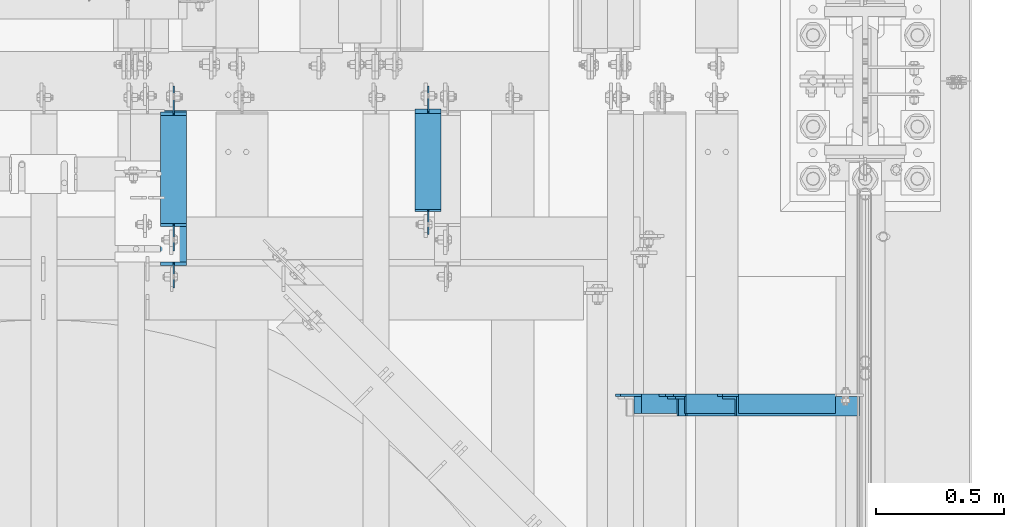
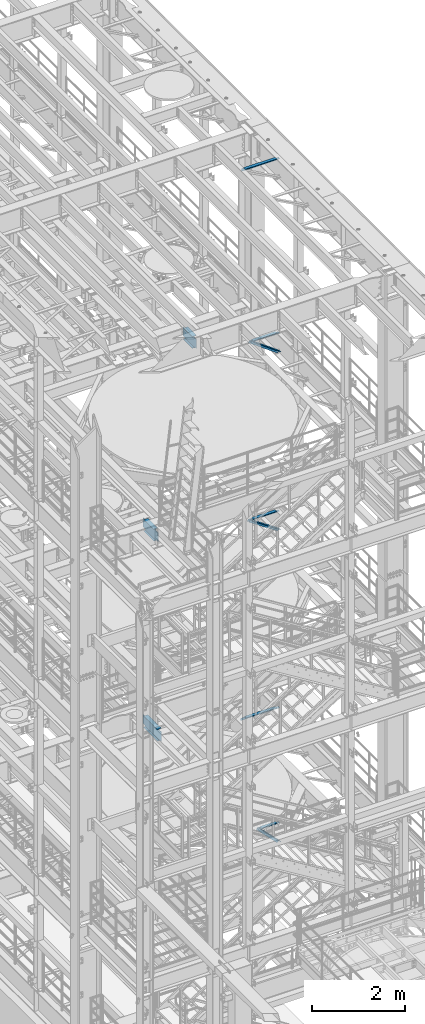
# One storey, part 1241 of 1876: 8 beams, 3 members, 11 elements without a shape of their own.
"""IFC2X3 building model written with IfcOpenShell, lengths in millimetres."""

from ifc_helpers import new_model, si_unit, frame, origin_with_axes, place, context, subcontext, project, spatial, faceted_brep, material, type_object, element, aggregate, save


model = new_model("IFC2X3")

# Units and contexts
model_context = context("Model", 3, precision=1e-05, world=origin_with_axes())
body_context = subcontext(model_context, "Body", "Model", "MODEL_VIEW")
ifc_project = project(units=[si_unit("LENGTHUNIT", "METRE", prefix="MILLI"), si_unit("AREAUNIT", "SQUARE_METRE"), si_unit("VOLUMEUNIT", "CUBIC_METRE"), si_unit("MASSUNIT", "GRAM", prefix="KILO"), si_unit("TIMEUNIT", "SECOND"), si_unit("PLANEANGLEUNIT", "RADIAN"), si_unit("SOLIDANGLEUNIT", "STERADIAN"), si_unit("THERMODYNAMICTEMPERATUREUNIT", "DEGREE_CELSIUS"), si_unit("LUMINOUSINTENSITYUNIT", "LUMEN")], contexts=[model_context])

# Site, building, storey
site_placement = place(None, origin_with_axes())
site = spatial("IfcSite", under=ifc_project, at=site_placement, CompositionType="ELEMENT")
building_placement = place(site_placement, origin_with_axes())
building = spatial("IfcBuilding", under=site, at=building_placement, Name="Undefined", CompositionType="ELEMENT")
storey_placement = place(building_placement, origin_with_axes())
storey = spatial("IfcBuildingStorey", under=building, at=storey_placement, Name="Undefined", CompositionType="ELEMENT", Elevation=0.0)

# Assembly, member
assembly_1_placement = place(storey_placement, origin_with_axes())
assembly_1 = element("IfcElementAssembly", 1, at=assembly_1_placement, inside=storey, AssemblyPlace="NOTDEFINED", PredefinedType="RIGID_FRAME")
ifc_material_1 = material(Name="STEEL/A36")
member_type = type_object("IfcMemberType", Name="L3X3X3/8", PredefinedType="NOTDEFINED")
member_1_placement = place(assembly_1_placement, frame((7040.82073558349, 257.175000000001, 5132.08684596299), z_axis=(0.0, -1.0, 0.0), x_axis=(0.701378051870177, 0.0, -0.712789469868064)))
member_1 = element("IfcMember", 2, at=member_1_placement, type_object=member_type, material=ifc_material_1, ObjectType="L3X3X3/8", context=body_context, shape_type="Brep", body=[
    faceted_brep([(758.761261852226, 28.5750000000353, 38.0999999999999), (758.761261852226, 28.5750000000353, -28.5749999999998), (758.761261852226, -38.0999999999494, -28.5749999999998), (758.761261852226, -38.0999999999494, -38.0999999999999), (758.761261852226, 38.1000000000313, -38.0999999999999), (758.761261852226, 38.1000000000313, 38.0999999999999), (72.7035731357846, 28.5749999999971, 38.0999999999999), (72.7035731357846, 28.5749999999971, -28.5749999999998), (72.7035731357837, -38.0999999999876, -28.5749999999998), (72.7035731357837, -38.0999999999876, -38.0999999999999), (72.7035731357851, 38.0999999999949, -38.0999999999999), (72.7035731357851, 38.0999999999949, 38.0999999999999)], [[[0, 1, 2, 3, 4, 5]], [[1, 0, 6, 7]], [[2, 1, 7, 8]], [[3, 2, 8, 9]], [[4, 3, 9, 10]], [[5, 4, 10, 11]], [[0, 5, 11, 6]], [[10, 9, 8, 7, 6, 11]]]),
])
aggregate(assembly_1, [member_1])

assembly_2_placement = place(storey_placement, origin_with_axes())
assembly_2 = element("IfcElementAssembly", 3, at=assembly_2_placement, inside=storey, AssemblyPlace="NOTDEFINED", PredefinedType="RIGID_FRAME")
member_2_placement = place(assembly_2_placement, frame((6816.45156900301, 257.175000000001, 17993.727144592), z_axis=(0.0, -1.0, 0.0), x_axis=(0.807030325960616, 0.0, -0.590509993971229)))
member_2 = element("IfcMember", 4, at=member_2_placement, type_object=member_type, material=ifc_material_1, ObjectType="L3X3X3/8", context=body_context, shape_type="Brep", body=[
    faceted_brep([(107.534166499222, 38.1000000000786, -38.0999999999999), (107.534166499222, 38.1000000000786, 38.0999999999999), (943.218892448816, 38.1000000010463, 38.0999999999999), (943.218892448816, 38.1000000010463, -38.0999999999999), (107.534166499204, 28.5750000000917, 38.0999999999999), (943.2188924488, 28.5750000010594, 38.0999999999999), (107.534166499204, 28.5750000000917, -28.5749999999998), (943.2188924488, 28.5750000010594, -28.5749999999998), (107.534166499082, -38.0999999998239, -28.5749999999998), (943.218892448681, -38.0999999988562, -28.5749999999998), (107.534166499082, -38.0999999998239, -38.0999999999999), (943.218892448681, -38.0999999988562, -38.0999999999999)], [[[0, 1, 2, 3]], [[1, 4, 5, 2]], [[4, 6, 7, 5]], [[6, 8, 9, 7]], [[8, 10, 11, 9]], [[10, 0, 3, 11]], [[5, 7, 9, 11, 3, 2]], [[10, 8, 6, 4, 1, 0]]]),
])
aggregate(assembly_2, [member_2])

assembly_3_placement = place(storey_placement, origin_with_axes())
assembly_3 = element("IfcElementAssembly", 5, at=assembly_3_placement, inside=storey, Name="BRACE", AssemblyPlace="NOTDEFINED", PredefinedType="RIGID_FRAME")
member_3_placement = place(assembly_3_placement, frame((6792.18717854508, 257.174999999999, 13303.4525776102), z_axis=(0.0, -1.0, 0.0), x_axis=(0.82801633589084, 0.0, -0.560703974926081)))
member_3 = element("IfcMember", 6, at=member_3_placement, type_object=member_type, material=ifc_material_1, Name="BRACE", ObjectType="L3X3X3/8", context=body_context, shape_type="Brep", body=[
    faceted_brep([(96.2629166569975, 38.0999999999149, -38.0999999999999), (96.2629166569975, 38.0999999999149, 38.0999999999999), (949.988805673232, 38.0999999993637, 38.0999999999999), (949.988805673232, 38.0999999993637, -38.0999999999999), (96.2629166570039, 28.5749999999189, 38.0999999999999), (949.98880567324, 28.5749999993659, 38.0999999999999), (96.2629166570039, 28.5749999999189, -28.5749999999998), (949.98880567324, 28.5749999993659, -28.5749999999998), (96.2629166570548, -38.1000000000404, -28.5749999999998), (949.98880567329, -38.1000000005952, -28.5749999999998), (96.2629166570548, -38.1000000000404, -38.0999999999999), (949.98880567329, -38.1000000005952, -38.0999999999999)], [[[0, 1, 2, 3]], [[1, 4, 5, 2]], [[4, 6, 7, 5]], [[6, 8, 9, 7]], [[8, 10, 11, 9]], [[10, 0, 3, 11]], [[5, 7, 9, 11, 3, 2]], [[10, 8, 6, 4, 1, 0]]]),
])
aggregate(assembly_3, [member_3])

# Assembly, beam
assembly_4_placement = place(storey_placement, origin_with_axes())
assembly_4 = element("IfcElementAssembly", 7, at=assembly_4_placement, inside=storey, Name="ANGLE", AssemblyPlace="NOTDEFINED", PredefinedType="RIGID_FRAME")
beam_type_1 = type_object("IfcBeamType", Name="L3X3X3/8", PredefinedType="NOTDEFINED")
beam_1_placement = place(assembly_4_placement, frame((6667.50000000095, 266.699999999997, 22517.1000001129), z_axis=(0.0, -1.0, 0.0), x_axis=(1.0, 0.0, 0.0)))
beam_1 = element("IfcBeam", 8, at=beam_1_placement, type_object=beam_type_1, material=ifc_material_1, Name="ANGLE", ObjectType="L3X3X3/8", context=body_context, shape_type="Brep", body=[
    faceted_brep([(836.613000301995, 28.5750000000007, -28.5749999999998), (836.613001168791, 28.5750000000007, 38.0999999999999), (52.3870335430847, 28.5750001907327, 38.0999999999858), (52.3869956588824, 28.5749999999955, -28.5750000000007), (836.613001168791, 38.0999999999985, 38.0999999999999), (52.387033543122, 38.0999999999985, 38.0999999999858), (15.8749936676099, 28.5749999999989, -28.5750000000007), (15.8749999382144, 28.5750001907327, -38.0999999999999), (3.17500012894925, 15.8750003814675, -38.0999999999999), (3.17500032897624, 15.8750003814675, -28.5749999999998), (52.3870393343063, 28.5750001907327, -38.1000000000149), (52.3869953826566, 38.0999999999954, -38.0999999999985), (836.613000178167, 38.0999999999985, -38.0999999999999), (836.613000301995, 12.6999991241828, -28.5749999999998), (836.613000178167, 12.6999991241828, -38.0999999999999), (913.60625591723, 12.6999991241828, -28.5749999999998), (913.606255793401, 12.6999991241828, -38.0999999999999), (945.35625591723, -19.0500008758172, -28.5749999999998), (945.356255793401, -19.0500008758172, -38.0999999999999), (945.356249999983, -38.0999999999985, -28.5749999999998), (945.356249999983, -38.0999999999985, -38.0999999999999), (3.17499999075153, -38.0999999999985, -28.5749999999998), (3.17499999075153, -38.0999999999985, -38.0999999999999), (3.17500012894925, 3.17500152587672, -38.0999999999999), (3.17500032897624, 3.17500152587672, -28.5749999999998)], [[[0, 1, 2, 3]], [[1, 4, 5, 2]], [[6, 7, 8, 9]], [[3, 10, 7, 6]], [[2, 5, 11, 10, 3]], [[4, 12, 11, 5]], [[1, 0, 13, 14, 12, 4]], [[15, 16, 14, 13]], [[16, 15, 17, 18]], [[18, 17, 19, 20]], [[20, 19, 21, 22]], [[8, 7, 10, 11, 12, 14, 16, 18, 20, 22, 23]], [[9, 8, 23, 24]], [[19, 17, 15, 13, 0, 3, 6, 9, 24, 21]], [[23, 22, 21, 24]]]),
])
aggregate(assembly_4, [beam_1])

assembly_5_placement = place(storey_placement, origin_with_axes())
assembly_5 = element("IfcElementAssembly", 9, at=assembly_5_placement, inside=storey, Name="ANGLE", AssemblyPlace="NOTDEFINED", PredefinedType="RIGID_FRAME")
beam_2_placement = place(assembly_5_placement, frame((6838.94981327725, 266.7, 17945.1), z_axis=(0.0, -1.0, 0.0), x_axis=(1.0, 0.0, 0.0)))
beam_2 = element("IfcBeam", 10, at=beam_2_placement, type_object=beam_type_1, material=ifc_material_1, Name="ANGLE", ObjectType="L3X3X3/8", context=body_context, shape_type="Brep", body=[
    faceted_brep([(665.163187024773, 28.5750000000007, -28.5749999999998), (665.163187891547, 28.5750000000007, 38.0999999999999), (84.137014014791, 28.5749999999998, 38.1000000000258), (84.1370001605219, 28.5749999999998, -28.5750000000007), (665.163187891547, 38.0999999999985, 38.0999999999999), (84.136999759924, 38.0999999999985, 38.0999999999999), (84.1369986264499, 22.2250007629373, -28.5749999999998), (84.1369984645216, 22.2250007629373, -38.0999999999999), (34.9250004786818, 22.2250007629373, -38.0999999999999), (34.9250006406101, 22.2250007629373, -28.5749999999998), (84.1369984645207, 38.0999999999985, -38.0999999999999), (665.163186900948, 38.0999999999985, -38.0999999999999), (665.163187024748, 12.6999992370475, -28.5749999999998), (665.16318690092, 12.6999992370475, -38.0999999999999), (742.156442639983, 12.6999992370475, -28.5749999999998), (742.156442516154, 12.6999992370475, -38.0999999999999), (773.906442639983, -19.0500007629525, -28.5749999999998), (773.906442516154, -19.0500007629525, -38.0999999999999), (773.906436722751, -38.0999999999985, -28.5749999999998), (773.906436722751, -38.0999999999985, -38.0999999999999), (3.17499999075153, -38.0999999999985, -28.5749999999998), (3.17499999075153, -38.0999999999985, -38.0999999999999), (3.1750004786818, -9.52499923706273, -38.0999999999999), (3.17500064061005, -9.52499923706273, -28.5749999999998)], [[[0, 1, 2, 3]], [[1, 4, 5, 2]], [[6, 7, 8, 9]], [[2, 5, 10, 7, 6, 3]], [[4, 11, 10, 5]], [[1, 0, 12, 13, 11, 4]], [[14, 15, 13, 12]], [[15, 14, 16, 17]], [[17, 16, 18, 19]], [[19, 18, 20, 21]], [[8, 7, 10, 11, 13, 15, 17, 19, 21, 22]], [[9, 8, 22, 23]], [[18, 16, 14, 12, 0, 3, 6, 9, 23, 20]], [[22, 21, 20, 23]]]),
])
aggregate(assembly_5, [beam_2])

assembly_6_placement = place(storey_placement, origin_with_axes())
assembly_6 = element("IfcElementAssembly", 11, at=assembly_6_placement, inside=storey, Name="ANGLE", AssemblyPlace="NOTDEFINED", PredefinedType="RIGID_FRAME")
beam_3_placement = place(assembly_6_placement, frame((6642.10000000027, 266.699999999997, 8115.3), z_axis=(0.0, -1.0, 0.0), x_axis=(1.0, 0.0, 0.0)))
beam_3 = element("IfcBeam", 12, at=beam_3_placement, type_object=beam_type_1, material=ifc_material_1, Name="ANGLE", ObjectType="L3X3X3/8", context=body_context, shape_type="Brep", body=[
    faceted_brep([(862.013000301767, 28.5749999999998, -28.5749999999998), (862.013001168541, 28.5749999999998, 38.0999999999999), (106.361999785874, 28.5749999999998, 38.0999999999999), (106.361998852422, 28.5749999999998, -28.5749999999998), (862.013001168541, 38.1000000000004, 38.0999999999999), (106.36199978587, 38.1000000000004, 38.0999999999999), (24.6062501036349, 20.6380008697515, -28.5749999999998), (24.6062499702866, 20.6380008697515, -38.0999999999999), (5.55625073322608, 1.58800163269098, -38.0999999999999), (5.55625086657437, 1.58800163269098, -28.5749999999998), (106.361998852423, 20.6380008697515, -28.5749999999998), (106.361998719075, 20.6380008697515, -38.0999999999999), (106.361998719068, 38.1000000000004, -38.0999999999999), (862.013000177942, 38.1000000000004, -38.0999999999999), (862.013000301742, 12.6999992370602, -28.5749999999998), (862.013000177913, 12.6999992370602, -38.0999999999999), (939.006248287582, 12.6999992370602, -28.5749999999998), (939.006248163753, 12.6999992370602, -38.0999999999999), (970.756248287582, -19.0500007629398, -28.5749999999998), (970.756248163753, -19.0500007629398, -38.0999999999999), (970.75624999973, -38.1000000000004, -28.5749999999998), (970.75624999973, -38.1000000000004, -38.0999999999999), (5.55625000000055, -38.1000000000004, -28.5749999999998), (5.55625000000055, -38.1000000000004, -38.1000000000004), (5.55625073322608, -4.76199874877875, -38.0999999999999), (5.55625086657437, -4.76199874877875, -28.5749999999998)], [[[0, 1, 2, 3]], [[1, 4, 5, 2]], [[6, 7, 8, 9]], [[10, 11, 7, 6]], [[2, 5, 12, 11, 10, 3]], [[4, 13, 12, 5]], [[1, 0, 14, 15, 13, 4]], [[16, 17, 15, 14]], [[17, 16, 18, 19]], [[19, 18, 20, 21]], [[21, 20, 22, 23]], [[8, 7, 11, 12, 13, 15, 17, 19, 21, 23, 24]], [[9, 8, 24, 25]], [[20, 18, 16, 14, 0, 3, 10, 6, 9, 25, 22]], [[24, 23, 22, 25]]]),
])
aggregate(assembly_6, [beam_3])

assembly_7_placement = place(storey_placement, origin_with_axes())
assembly_7 = element("IfcElementAssembly", 13, at=assembly_7_placement, inside=storey, Name="ANGLE", AssemblyPlace="NOTDEFINED", PredefinedType="RIGID_FRAME")
beam_4_placement = place(assembly_7_placement, frame((7042.15, 266.699999999999, 5092.7), z_axis=(0.0, -1.0, 0.0), x_axis=(1.0, 0.0, 0.0)))
beam_4 = element("IfcBeam", 14, at=beam_4_placement, type_object=beam_type_1, material=ifc_material_1, Name="ANGLE", ObjectType="L3X3X3/8", context=body_context, shape_type="Brep", body=[
    faceted_brep([(461.963000256203, 28.5750000000007, -28.5749999999998), (461.963001056292, 28.5750000000007, 38.0999999999999), (84.1370686928021, 28.5750001907327, 38.100000000024), (84.1370606917826, 28.5750000000007, -28.5749999999771), (461.963001056292, 38.1000000000004, 38.0999999999999), (84.1374011325761, 38.0999999999985, 38.0999999999776), (22.2249552881549, 26.9870083863452, -28.5749999999935), (22.2249551643299, 26.9870094055232, -38.0999999999931), (3.17495592726937, 7.93701016846171, -38.0999999999995), (3.17495605109434, 7.93700914928468, -28.5749999999989), (84.1369575769495, 26.9870083863452, -28.5749999999744), (84.1369574531245, 26.9870094055223, -38.099999999974), (84.137408980816, 38.0999999999985, -38.1000000000231), (461.963000141903, 38.1000000000004, -38.0999999999999), (461.963000302011, 12.6999992370611, -28.5749999999998), (461.963000178182, 12.6999992370611, -38.0999999999999), (538.956248287851, 12.6999992370611, -28.5749999999998), (538.956248164022, 12.6999992370611, -38.0999999999999), (570.706248287851, -19.0500007629389, -28.5749999999998), (570.706248164022, -19.0500007629389, -38.0999999999999), (570.706249999999, -38.1000000000004, -28.5749999999998), (570.706249999999, -38.1000000000004, -38.0999999999999), (3.17499999075153, -38.0999999999985, -28.5749999999998), (3.17499999075153, -38.0999999999985, -38.0999999999999), (3.17495592726937, 1.58700978699198, -38.0999999999995), (3.17495605109434, 1.58700876781495, -28.5749999999989)], [[[0, 1, 2, 3]], [[1, 4, 5, 2]], [[6, 7, 8, 9]], [[10, 11, 7, 6]], [[2, 5, 12, 11, 10, 3]], [[4, 13, 12, 5]], [[1, 0, 14, 15, 13, 4]], [[16, 17, 15, 14]], [[17, 16, 18, 19]], [[19, 18, 20, 21]], [[21, 20, 22, 23]], [[8, 7, 11, 12, 13, 15, 17, 19, 21, 23, 24]], [[9, 8, 24, 25]], [[20, 18, 16, 14, 0, 3, 10, 6, 9, 25, 22]], [[24, 23, 22, 25]]]),
])
aggregate(assembly_7, [beam_4])

assembly_8_placement = place(storey_placement, origin_with_axes())
assembly_8 = element("IfcElementAssembly", 15, at=assembly_8_placement, inside=storey, Name="ANGLE", AssemblyPlace="NOTDEFINED", PredefinedType="RIGID_FRAME")
beam_5_placement = place(assembly_8_placement, frame((6813.54999999327, 266.699999999999, 13271.4999999928), z_axis=(0.0, -1.0, 0.0), x_axis=(1.0, 0.0, 0.0)))
beam_5 = element("IfcBeam", 16, at=beam_5_placement, type_object=beam_type_1, material=ifc_material_1, Name="ANGLE", ObjectType="L3X3X3/8", context=body_context, shape_type="Brep", body=[
    faceted_brep([(690.56300030954, 28.5750000000007, -28.5749999999998), (690.563001176313, 28.5750000000007, 38.0999999999999), (103.186999799132, 28.5750000000007, 38.0999999999999), (103.186998865692, 28.5750000000007, -28.5749999999998), (690.563001175733, 38.1000000000004, 38.0999999999999), (103.186999799132, 38.1000000000004, 38.0999999999999), (103.186998865692, 22.2250007629391, -28.5749999999998), (103.186998732343, 22.2250007629391, -38.0999999999999), (29.3687518909128, 22.2250007629391, -38.0999999999999), (29.3687520242611, 22.2250007629391, -28.5749999999998), (103.186998732343, 38.1000000000004, -38.0999999999999), (690.563000185135, 38.1000000000004, -38.0999999999999), (690.563000310482, 12.6999992442816, -28.5749999999998), (690.563000186654, 12.6999992442816, -38.0999999999999), (767.556248294582, 12.6999992442816, -28.5749999999998), (767.556248170753, 12.6999992442816, -38.0999999999999), (799.306248294582, -19.0500007557184, -28.5749999999998), (799.306248170753, -19.0500007557184, -38.0999999999999), (799.30625000673, -38.1000000000004, -28.5749999999998), (799.30625000673, -38.1000000000004, -38.0999999999999), (3.96875000000273, -38.1000000000004, -28.5749999999998), (3.96875000000273, -38.1000000000004, -38.0999999999999), (3.96875227238252, -3.17500076293982, -38.0999999999999), (3.96875240573081, -3.17500076293982, -28.5749999999998)], [[[0, 1, 2, 3]], [[1, 4, 5, 2]], [[6, 7, 8, 9]], [[2, 5, 10, 7, 6, 3]], [[4, 11, 10, 5]], [[1, 0, 12, 13, 11, 4]], [[14, 15, 13, 12]], [[15, 14, 16, 17]], [[17, 16, 18, 19]], [[19, 18, 20, 21]], [[8, 7, 10, 11, 13, 15, 17, 19, 21, 22]], [[9, 8, 22, 23]], [[18, 16, 14, 12, 0, 3, 6, 9, 23, 20]], [[22, 21, 20, 23]]]),
])
aggregate(assembly_8, [beam_5])

assembly_9_placement = place(storey_placement, origin_with_axes())
assembly_9 = element("IfcElementAssembly", 17, at=assembly_9_placement, inside=storey, Name="BEAM", AssemblyPlace="NOTDEFINED", PredefinedType="RIGID_FRAME")
ifc_material_2 = material(Name="STEEL/A992")
beam_type_2 = type_object("IfcBeamType", Name="W12X16", PredefinedType="NOTDEFINED")
beam_6_placement = place(assembly_9_placement, frame((5918.2, 762.0, 17830.8), z_axis=(0.0, 0.0, 1.0), x_axis=(0.0, 1.0, 0.0)))
beam_6 = element("IfcBeam", 18, at=beam_6_placement, type_object=beam_type_2, material=ifc_material_2, Name="BEAM", ObjectType="W12X16", context=body_context, shape_type="Brep", body=[
    faceted_brep([(165.099999999456, -3.17500000000018, -127.0), (165.099999999456, 3.17500000000018, -127.0), (241.30000019019, 3.17500002282031, -127.0), (241.30000019019, -3.17500000000018, -127.0), (246.160079708236, 3.17500002297311, -127.966729922588), (246.160079708236, -3.17500000000018, -127.966729922588), (250.280256176389, 3.17500002339239, -130.719743823065), (250.280256176389, -3.17500000000018, -130.719743823065), (253.033270076867, 3.17500002401448, -134.839920291219), (253.033270076867, -3.17500000000018, -134.839920291219), (253.999999999455, -3.17500000000018, -139.699999809265), (253.999999999455, 3.17500002474299, -139.699999809265), (253.999999999455, 3.17500009242758, -146.049999999999), (253.999999999455, 50.8000000000002, -146.049999999999), (253.999999999455, 50.8000000000002, -152.400000000001), (253.999999999455, -50.8000000000002, -152.400000000001), (253.999999999455, -50.8000000000002, -146.049999999999), (253.999999999455, -3.17500000000018, -146.049999999999), (635.79375, 50.8000000000002, 146.049999999999), (635.79375, 3.17500000000018, 146.049999999999), (261.937499999455, 3.17500000000018, 146.049999999999), (261.937499999455, 50.8000000000002, 146.049999999999), (249.23750019019, -3.17500000000018, 120.650000000001), (249.23750019019, 3.17499998659878, 120.650000000001), (165.099999999456, 3.17500000000018, 120.650000000001), (165.099999999456, -3.17500000000018, 120.650000000001), (254.097579708236, -3.17500000000018, 121.616729922589), (254.097579708236, 3.17499998645872, 121.616729922589), (258.217756176389, -3.17500000000018, 124.369743823067), (258.217756176389, 3.17499998605672, 124.369743823067), (260.970770076867, -3.17500000000018, 128.48992029122), (260.970770076867, 3.17499998545372, 128.48992029122), (261.937499999455, -3.17500000000018, 133.349999809267), (261.937499999455, 3.17499998474068, 133.349999809267), (635.79375, -50.8000000000002, 152.400000000001), (635.79375, 50.8000000000002, 152.400000000001), (261.937499999455, 50.8000000000002, 152.400000000001), (261.937499999455, -50.8000000000002, 152.400000000001), (635.79375, -50.8000000000002, 146.049999999999), (261.937499999455, -50.8000000000002, 146.049999999999), (635.79375, -3.17500000000018, 146.049999999999), (261.937499999455, -3.17500000000018, 146.049999999999), (635.79375, -3.17500000000018, 120.64999980927), (635.79375, 3.17500000000018, 120.64999980927), (636.760479922588, -3.17500000000018, 115.789920291223), (636.760479922588, 3.17500000000018, 115.789920291223), (639.513493823066, -3.17500000000018, 111.669743823069), (639.513493823066, 3.17500000000018, 111.669743823069), (643.633670291219, -3.17500000000018, 108.916729922592), (643.633670291219, 3.17500000000018, 108.916729922592), (648.493749809265, -3.17500000000018, 107.950000000004), (648.493749809265, 3.17500000000018, 107.950000000004), (742.15625, -3.17500000000018, 107.950000000004), (742.15625, 3.17500000000018, 107.950000000004), (742.15625, -3.17500000000018, -126.999999999996), (742.15625, 3.17500000000018, -126.999999999996), (665.956249809265, -3.17500000000018, -126.999999999996), (665.956249809265, 3.17500000000018, -126.999999999996), (661.09617029122, -3.17500000000018, -127.966729922584), (661.09617029122, 3.17500000000018, -127.966729922584), (656.975993823066, -3.17500000000018, -130.719743823061), (656.975993823066, 3.17500000000018, -130.719743823061), (654.222979922588, -3.17500000000018, -134.839920291215), (654.222979922588, 3.17500000000018, -134.839920291215), (653.25625, -3.17500000000018, -139.699999809261), (653.25625, 3.17500000000018, -139.699999809261), (653.25625, -3.17500000000018, -146.049999999999), (653.25625, -50.8000000000002, -146.049999999999), (653.25625, -50.8000000000002, -152.400000000001), (653.25625, 50.8000000000002, -152.400000000001), (653.25625, 50.8000000000002, -146.049999999999), (653.25625, 3.17500000000018, -146.049999999999)], [[[0, 1, 2, 3]], [[3, 2, 4, 5]], [[5, 4, 6, 7]], [[7, 6, 8, 9]], [[10, 11, 12, 13, 14, 15, 16, 17]], [[9, 8, 11, 10]], [[18, 19, 20, 21]], [[22, 23, 24, 25]], [[26, 27, 23, 22]], [[28, 29, 27, 26]], [[30, 31, 29, 28]], [[32, 33, 31, 30]], [[34, 35, 36, 37]], [[38, 34, 37, 39]], [[40, 38, 39, 41]], [[37, 36, 21, 20, 33, 32, 41, 39]], [[35, 18, 21, 36]], [[34, 38, 40, 42, 43, 19, 18, 35]], [[44, 45, 43, 42]], [[46, 47, 45, 44]], [[48, 49, 47, 46]], [[50, 51, 49, 48]], [[52, 53, 51, 50]], [[53, 52, 54, 55]], [[54, 56, 57, 55]], [[58, 59, 57, 56]], [[60, 61, 59, 58]], [[62, 63, 61, 60]], [[64, 65, 63, 62]], [[66, 67, 68, 69, 70, 71, 65, 64]], [[67, 66, 17, 16]], [[68, 67, 16, 15]], [[69, 68, 15, 14]], [[70, 69, 14, 13]], [[71, 70, 13, 12]], [[6, 4, 2, 1, 24, 23, 27, 29, 31, 33, 20, 19, 43, 45, 47, 49, 51, 53, 55, 57, 59, 61, 63, 65, 71, 12, 11, 8]], [[25, 24, 1, 0]], [[66, 64, 62, 60, 58, 56, 54, 52, 50, 48, 46, 44, 42, 40, 41, 32, 30, 28, 26, 22, 25, 0, 3, 5, 7, 9, 10, 17]]]),
])
aggregate(assembly_9, [beam_6])

assembly_10_placement = place(storey_placement, origin_with_axes())
assembly_10 = element("IfcElementAssembly", 19, at=assembly_10_placement, inside=storey, Name="BEAM", AssemblyPlace="NOTDEFINED", PredefinedType="RIGID_FRAME")
beam_7_placement = place(assembly_10_placement, frame((4927.6, 762.0, 13157.2), z_axis=(0.0, 0.0, 1.0), x_axis=(0.0, 1.0, 0.0)))
beam_7 = element("IfcBeam", 20, at=beam_7_placement, type_object=beam_type_2, material=ifc_material_2, Name="BEAM", ObjectType="W12X16", context=body_context, shape_type="Brep", body=[
    faceted_brep([(99.2187500000005, -3.17500000000018, -127.0), (99.2187500000005, 3.17500000000018, -127.0), (181.768750190735, 3.17500000000018, -127.0), (181.768750190735, -3.17500000000018, -127.0), (186.628829708781, 3.17500000000018, -127.966729922588), (186.628829708781, -3.17500000000018, -127.966729922588), (190.749006176934, 3.17500000000018, -130.719743823065), (190.749006176934, -3.17500000000018, -130.719743823065), (193.502020077412, 3.17500000000018, -134.839920291219), (193.502020077412, -3.17500000000018, -134.839920291219), (194.46875, -3.17500000000018, -139.699999809265), (194.46875, 3.17500000000018, -139.699999809265), (194.46875, 3.17500000000018, -146.049999999999), (194.46875, 50.8000000000002, -146.049999999999), (194.46875, 50.8000000000002, -152.4), (194.46875, -50.8000000000002, -152.4), (194.46875, -50.8000000000002, -146.049999999999), (194.46875, -3.17500000000018, -146.049999999999), (627.85625, 50.8000000000002, 146.049999999999), (627.85625, 3.17500000000018, 146.049999999999), (207.16875, 3.17500000000018, 146.049999999999), (207.16875, 50.8000000000002, 146.049999999999), (194.468750190735, -3.17500000000018, 114.299999999999), (194.468750190735, 3.17500000000018, 114.299999999999), (99.2187500000005, 3.17500000000018, 114.299999999999), (99.2187500000005, -3.17500000000018, 114.299999999999), (199.328829708781, -3.17500000000018, 115.266729922587), (199.328829708781, 3.17500000000018, 115.266729922587), (203.449006176934, -3.17500000000018, 118.019743823064), (203.449006176934, 3.17500000000018, 118.019743823064), (206.202020077412, -3.17500000000018, 122.139920291218), (206.202020077412, 3.17500000000018, 122.139920291218), (207.16875, -3.17500000000018, 126.999999809264), (207.16875, 3.17500000000018, 126.999999809264), (627.85625, -50.8000000000002, 152.4), (627.85625, 50.8000000000002, 152.4), (207.16875, 50.8000000000002, 152.4), (207.16875, -50.8000000000002, 152.4), (627.85625, -50.8000000000002, 146.049999999999), (207.16875, -50.8000000000002, 146.049999999999), (627.85625, -3.17500000000018, 146.049999999999), (207.16875, -3.17500000000018, 146.049999999999), (627.85625, -3.17500000000018, 126.999999809264), (627.85625, 3.17500000000018, 126.999999809264), (628.822979922588, -3.17500000000018, 122.139920291218), (628.822979922588, 3.17500000000018, 122.139920291218), (631.575993823066, -3.17500000000018, 118.019743823064), (631.575993823066, 3.17500000000018, 118.019743823064), (635.696170291219, -3.17500000000018, 115.266729922587), (635.696170291219, 3.17500000000018, 115.266729922587), (640.556249809265, -3.17500000000018, 114.299999999999), (640.556249809265, 3.17500000000018, 114.299999999999), (742.15625, -3.17500000000018, 114.299999999999), (742.15625, 3.17500000000018, 114.299999999999), (742.15625, -3.17500000000018, -126.999999999996), (742.15625, 3.17500000000018, -126.999999999996), (653.256249809265, -3.17500000000018, -127.0), (653.256249809265, 3.17500000000018, -127.0), (648.39617029122, -3.17500000000018, -127.966729922588), (648.39617029122, 3.17500000000018, -127.966729922588), (644.275993823066, -3.17500000000018, -130.719743823065), (644.275993823066, 3.17500000000018, -130.719743823065), (641.522979922588, -3.17500000000018, -134.839920291219), (641.522979922588, 3.17500000000018, -134.839920291219), (640.55625, -3.17500000000018, -139.699999809265), (640.55625, 3.17500000000018, -139.699999809265), (640.55625, -3.17500000000018, -146.049999999999), (640.55625, -50.8000000000002, -146.049999999999), (640.55625, -50.8000000000002, -152.4), (640.55625, 50.8000000000002, -152.4), (640.55625, 50.8000000000002, -146.049999999999), (640.55625, 3.17500000000018, -146.049999999999)], [[[0, 1, 2, 3]], [[3, 2, 4, 5]], [[5, 4, 6, 7]], [[7, 6, 8, 9]], [[10, 11, 12, 13, 14, 15, 16, 17]], [[9, 8, 11, 10]], [[18, 19, 20, 21]], [[22, 23, 24, 25]], [[26, 27, 23, 22]], [[28, 29, 27, 26]], [[30, 31, 29, 28]], [[32, 33, 31, 30]], [[34, 35, 36, 37]], [[38, 34, 37, 39]], [[40, 38, 39, 41]], [[37, 36, 21, 20, 33, 32, 41, 39]], [[35, 18, 21, 36]], [[34, 38, 40, 42, 43, 19, 18, 35]], [[44, 45, 43, 42]], [[46, 47, 45, 44]], [[48, 49, 47, 46]], [[50, 51, 49, 48]], [[52, 53, 51, 50]], [[53, 52, 54, 55]], [[54, 56, 57, 55]], [[58, 59, 57, 56]], [[60, 61, 59, 58]], [[62, 63, 61, 60]], [[64, 65, 63, 62]], [[66, 67, 68, 69, 70, 71, 65, 64]], [[67, 66, 17, 16]], [[68, 67, 16, 15]], [[69, 68, 15, 14]], [[70, 69, 14, 13]], [[71, 70, 13, 12]], [[6, 4, 2, 1, 24, 23, 27, 29, 31, 33, 20, 19, 43, 45, 47, 49, 51, 53, 55, 57, 59, 61, 63, 65, 71, 12, 11, 8]], [[25, 24, 1, 0]], [[66, 64, 62, 60, 58, 56, 54, 52, 50, 48, 46, 44, 42, 40, 41, 32, 30, 28, 26, 22, 25, 0, 3, 5, 7, 9, 10, 17]]]),
])
aggregate(assembly_10, [beam_7])

assembly_11_placement = place(storey_placement, origin_with_axes())
assembly_11 = element("IfcElementAssembly", 21, at=assembly_11_placement, inside=storey, Name="BEAM", AssemblyPlace="NOTDEFINED", PredefinedType="RIGID_FRAME")
beam_8_placement = place(assembly_11_placement, frame((4927.6, 863.6, 8001.0), z_axis=(0.0, 0.0, 1.0), x_axis=(0.0, 1.0, 0.0)))
beam_8 = element("IfcBeam", 22, at=beam_8_placement, type_object=beam_type_2, material=ifc_material_2, Name="BEAM", ObjectType="W12X16", context=body_context, shape_type="Brep", body=[
    faceted_brep([(-146.645312, -3.17500000000018, -126.999999999999), (-146.645312, 3.17500000000018, -126.999999999999), (-70.4453118092653, 3.17500000000018, -126.999999999999), (-70.4453118092653, -3.17500000000018, -126.999999999999), (-65.5852322912197, 3.17500000000018, -127.966729922587), (-65.5852322912197, -3.17500000000018, -127.966729922587), (-61.465055823066, 3.17500000000018, -130.719743823065), (-61.465055823066, -3.17500000000018, -130.719743823065), (-58.712041922588, 3.17500000000018, -134.839920291219), (-58.712041922588, -3.17500000000018, -134.839920291219), (-57.7453120000001, -3.17500000000018, -139.699999809264), (-57.7453120000001, 3.17500000000018, -139.699999809264), (-57.7453120000001, 3.17500000000018, -146.05), (-57.7453120000001, 50.8000000000002, -146.05), (-57.7453120000001, 50.8000000000002, -152.4), (-57.7453120000001, -50.8000000000002, -152.4), (-57.7453120000001, -50.8000000000002, -146.05), (-57.7453120000001, -3.17500000000018, -146.05), (532.60625, 50.8000000000002, 146.05), (532.60625, 3.17500000000018, 146.05), (-45.0453120000001, 3.17500000000018, 146.05), (-45.0453120000001, 50.8000000000002, 146.05), (-57.7453118092652, -3.17500000000018, 120.650000000001), (-57.7453118092652, 3.17500000000018, 120.650000000001), (-146.645312, 3.17500000000018, 120.650000000001), (-146.645312, -3.17500000000018, 120.650000000001), (-52.8852322912196, -3.17500000000018, 121.616729922588), (-52.8852322912196, 3.17500000000018, 121.616729922588), (-48.7650558230659, -3.17500000000018, 124.369743823067), (-48.7650558230659, 3.17500000000018, 124.369743823067), (-46.012041922588, -3.17500000000018, 128.48992029122), (-46.012041922588, 3.17500000000018, 128.48992029122), (-45.0453120000001, -3.17500000000018, 133.349999809266), (-45.0453120000001, 3.17500000000018, 133.349999809266), (532.60625, -50.8000000000002, 152.4), (532.60625, 50.8000000000002, 152.4), (-45.0453120000001, 50.8000000000002, 152.4), (-45.0453120000001, -50.8000000000002, 152.4), (532.60625, -50.8000000000002, 146.05), (-45.0453120000001, -50.8000000000002, 146.05), (532.60625, -3.17500000000018, 146.05), (-45.0453120000001, -3.17500000000018, 146.05), (532.60625, -3.17500000000018, 126.999999809264), (532.60625, 3.17500000000018, 126.999999809264), (533.572979922587, -3.17500000000018, 122.139920291219), (533.572979922587, 3.17500000000018, 122.139920291219), (536.325993823065, -3.17500000000018, 118.019743823065), (536.325993823065, 3.17500000000018, 118.019743823065), (540.446170291219, -3.17500000000018, 115.266729922587), (540.446170291219, 3.17500000000018, 115.266729922587), (545.306249809265, -3.17500000000018, 114.299999999999), (545.306249809265, 3.17500000000018, 114.299999999999), (640.556249809265, -3.17500000000018, 114.299999999999), (640.556249809265, 3.17500000000018, 114.299999999999), (640.556249999999, -3.17500000000018, -127.000000000001), (640.556249999999, 3.17500000000018, -127.000000000001), (558.006249809265, -3.17500000000018, -127.000000000001), (558.006249809265, 3.17500000000018, -127.000000000001), (553.146170291219, -3.17500000000018, -127.966729922588), (553.146170291219, 3.17500000000018, -127.966729922588), (549.025993823066, -3.17500000000018, -130.719743823067), (549.025993823066, 3.17500000000018, -130.719743823067), (546.272979922587, -3.17500000000018, -134.839920291221), (546.272979922587, 3.17500000000018, -134.839920291221), (545.30625, -3.17500000000018, -139.699999809266), (545.30625, 3.17500000000018, -139.699999809266), (545.30625, -3.17500000000018, -146.05), (545.30625, -50.8000000000002, -146.05), (545.30625, -50.8000000000002, -152.4), (545.30625, 50.8000000000002, -152.4), (545.30625, 50.8000000000002, -146.05), (545.30625, 3.17500000000018, -146.05)], [[[0, 1, 2, 3]], [[3, 2, 4, 5]], [[5, 4, 6, 7]], [[7, 6, 8, 9]], [[10, 11, 12, 13, 14, 15, 16, 17]], [[9, 8, 11, 10]], [[18, 19, 20, 21]], [[22, 23, 24, 25]], [[26, 27, 23, 22]], [[28, 29, 27, 26]], [[30, 31, 29, 28]], [[32, 33, 31, 30]], [[34, 35, 36, 37]], [[38, 34, 37, 39]], [[40, 38, 39, 41]], [[37, 36, 21, 20, 33, 32, 41, 39]], [[35, 18, 21, 36]], [[34, 38, 40, 42, 43, 19, 18, 35]], [[44, 45, 43, 42]], [[46, 47, 45, 44]], [[48, 49, 47, 46]], [[50, 51, 49, 48]], [[52, 53, 51, 50]], [[53, 52, 54, 55]], [[54, 56, 57, 55]], [[58, 59, 57, 56]], [[60, 61, 59, 58]], [[62, 63, 61, 60]], [[64, 65, 63, 62]], [[66, 67, 68, 69, 70, 71, 65, 64]], [[67, 66, 17, 16]], [[68, 67, 16, 15]], [[69, 68, 15, 14]], [[70, 69, 14, 13]], [[71, 70, 13, 12]], [[6, 4, 2, 1, 24, 23, 27, 29, 31, 33, 20, 19, 43, 45, 47, 49, 51, 53, 55, 57, 59, 61, 63, 65, 71, 12, 11, 8]], [[25, 24, 1, 0]], [[66, 64, 62, 60, 58, 56, 54, 52, 50, 48, 46, 44, 42, 40, 41, 32, 30, 28, 26, 22, 25, 0, 3, 5, 7, 9, 10, 17]]]),
])
aggregate(assembly_11, [beam_8])

save(model, "model.ifc")
